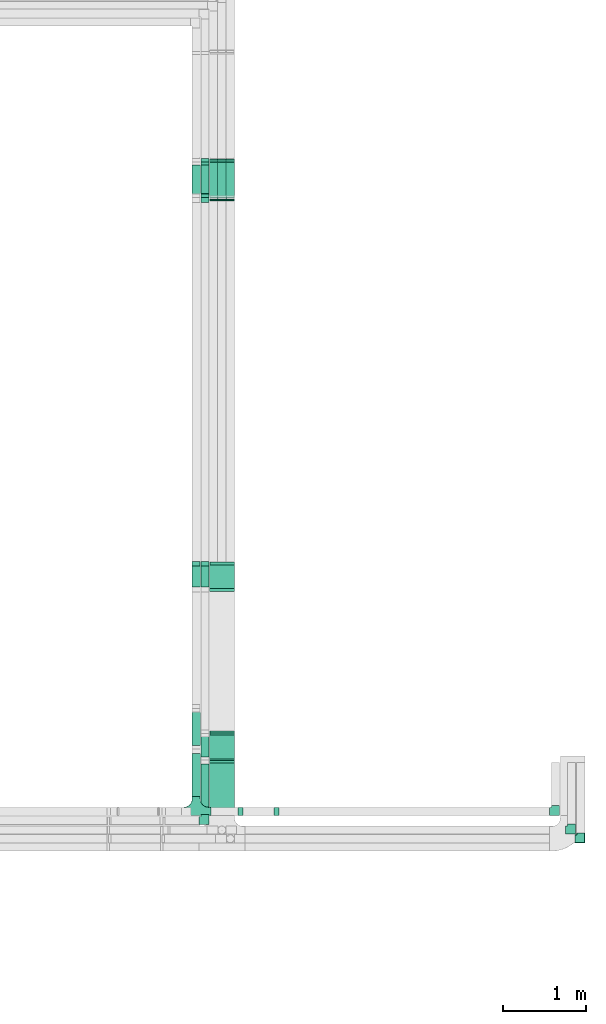
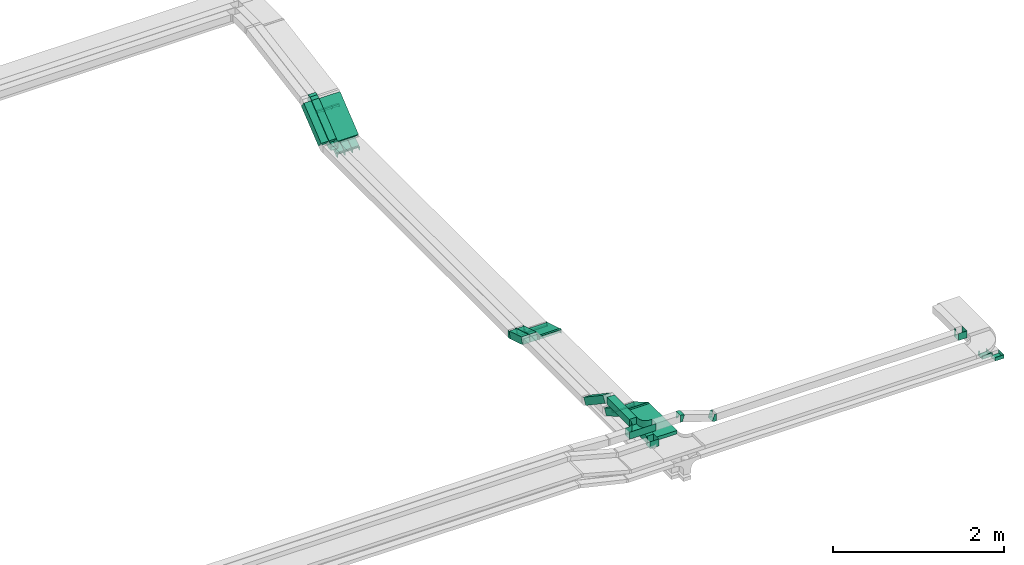
# One storey, part 11 of 14: 21 flow fittings, 15 flow segments.
"""IFC2X3 building model written with IfcOpenShell, lengths in millimetres."""

from ifc_helpers import new_model, entity, si_unit, converted_unit, derived_unit, direction, frame, frame_2d, origin, origin_2d_with_axis, place, context, subcontext, project, spatial, rectangle, extrude, faceted_brep, source, transform, mapped, material, type_object, type_shapes, element, save


model = new_model("IFC2X3")

# Units and contexts
model_context = context("Model", 3, precision=0.01, world=origin(), true_north=direction((6.12303176911189e-17, 1.0)))
body_context = subcontext(model_context, "Body", "Model", "MODEL_VIEW")
ifc_project = project(units=[si_unit("LENGTHUNIT", "METRE", prefix="MILLI"), si_unit("AREAUNIT", "SQUARE_METRE"), si_unit("VOLUMEUNIT", "CUBIC_METRE"), converted_unit("PLANEANGLEUNIT", "DEGREE", entity("IfcRatioMeasure", 0.0174532925199433), si_unit("PLANEANGLEUNIT", "RADIAN"), dimensions=[0, 0, 0, 0, 0, 0, 0]), si_unit("MASSUNIT", "GRAM", prefix="KILO"), derived_unit("MASSDENSITYUNIT", [(si_unit("MASSUNIT", "GRAM", prefix="KILO"), 1), (si_unit("LENGTHUNIT", "METRE"), -3)]), derived_unit("MOMENTOFINERTIAUNIT", [(si_unit("LENGTHUNIT", "METRE"), 4)]), si_unit("TIMEUNIT", "SECOND"), si_unit("FREQUENCYUNIT", "HERTZ"), si_unit("THERMODYNAMICTEMPERATUREUNIT", "DEGREE_CELSIUS"), derived_unit("THERMALTRANSMITTANCEUNIT", [(si_unit("MASSUNIT", "GRAM", prefix="KILO"), 1), (si_unit("THERMODYNAMICTEMPERATUREUNIT", "KELVIN"), -1), (si_unit("TIMEUNIT", "SECOND"), -3)]), derived_unit("VOLUMETRICFLOWRATEUNIT", [(si_unit("LENGTHUNIT", "METRE"), 3), (si_unit("TIMEUNIT", "SECOND"), -1)]), derived_unit("MASSFLOWRATEUNIT", [(si_unit("MASSUNIT", "GRAM", prefix="KILO"), 1), (si_unit("TIMEUNIT", "SECOND"), -1)]), derived_unit("ROTATIONALFREQUENCYUNIT", [(si_unit("TIMEUNIT", "SECOND"), -1)]), si_unit("ELECTRICCURRENTUNIT", "AMPERE"), si_unit("ELECTRICVOLTAGEUNIT", "VOLT"), si_unit("POWERUNIT", "WATT"), si_unit("FORCEUNIT", "NEWTON", prefix="KILO"), si_unit("ILLUMINANCEUNIT", "LUX"), si_unit("LUMINOUSFLUXUNIT", "LUMEN"), si_unit("LUMINOUSINTENSITYUNIT", "CANDELA"), derived_unit("USERDEFINED", [(si_unit("MASSUNIT", "GRAM", prefix="KILO"), -1), (si_unit("LENGTHUNIT", "METRE"), -2), (si_unit("TIMEUNIT", "SECOND"), 3), (si_unit("LUMINOUSFLUXUNIT", "LUMEN"), 1)]), derived_unit("LINEARVELOCITYUNIT", [(si_unit("LENGTHUNIT", "METRE"), 1), (si_unit("TIMEUNIT", "SECOND"), -1)]), si_unit("PRESSUREUNIT", "PASCAL"), derived_unit("USERDEFINED", [(si_unit("LENGTHUNIT", "METRE"), -2), (si_unit("MASSUNIT", "GRAM", prefix="KILO"), 1), (si_unit("TIMEUNIT", "SECOND"), -2)]), derived_unit("LINEARFORCEUNIT", [(si_unit("MASSUNIT", "GRAM", prefix="KILO"), 1), (si_unit("LENGTHUNIT", "METRE"), 1), (si_unit("TIMEUNIT", "SECOND"), -2), (si_unit("LENGTHUNIT", "METRE"), -1)]), derived_unit("PLANARFORCEUNIT", [(si_unit("MASSUNIT", "GRAM", prefix="KILO"), 1), (si_unit("LENGTHUNIT", "METRE"), 1), (si_unit("TIMEUNIT", "SECOND"), -2), (si_unit("LENGTHUNIT", "METRE"), -2)])], contexts=[model_context])

# Site, building, storey
site_placement = place(None, origin())
site = spatial("IfcSite", under=ifc_project, at=site_placement, CompositionType="ELEMENT")
building_placement = place(site_placement, origin())
building = spatial("IfcBuilding", under=site, at=building_placement, CompositionType="ELEMENT")
storey_placement = place(building_placement, frame((0.0, 0.0, 19800.0)))
storey = spatial("IfcBuildingStorey", under=building, at=storey_placement, CompositionType="ELEMENT", Elevation=19800.0)

# Flow segments
cable_carrier_segment_type = type_object("IfcCableCarrierSegmentType", PredefinedType="CABLETRAYSEGMENT")
flow_segment_1_placement = place(storey_placement, frame((64391.91, 17411.15, 2720.97)))
element("IfcFlowSegment", 1, at=flow_segment_1_placement, inside=storey, type_object=cable_carrier_segment_type, context=body_context, shape_type="SweptSolid", body=[
    extrude(rectangle(XDim=49.9999999999999, YDim=558.364474472639, at=frame_2d((0.0, 0.0), x_axis=(0.0, 1.0))), frame((0.0, 232.7, 195.12), z_axis=(1.0, 0.0, 0.0), x_axis=(0.0, -0.777145961456977, -0.62932039104983)), (0.0, 0.0, 1.0), 300.000000000001),
])
flow_segment_2_placement = place(storey_placement, frame((64285.53, 17401.05, 2737.88)))
element("IfcFlowSegment", 2, at=flow_segment_2_placement, inside=storey, type_object=cable_carrier_segment_type, context=body_context, shape_type="SweptSolid", body=[
    extrude(rectangle(XDim=100.000000000002, YDim=99.9999999999916, at=origin_2d_with_axis()), frame((50.02, 31.47, 38.86), z_axis=(-3.20308930122839e-05, 0.777145960996682, 0.6293203908031), x_axis=(0.0, -0.629320391125934, 0.777145961395349)), (0.0, 0.0, 1.0), 524.408740760887),
])
flow_segment_3_placement = place(storey_placement, frame((64180.06, 17401.05, 2737.88)))
element("IfcFlowSegment", 3, at=flow_segment_3_placement, inside=storey, type_object=cable_carrier_segment_type, context=body_context, shape_type="SweptSolid", body=[
    extrude(rectangle(XDim=100.000000000001, YDim=99.9999999999946, at=origin_2d_with_axis()), frame((50.0, 31.47, 38.86), z_axis=(0.0, 0.777145961456953, 0.62932039104986), x_axis=(0.0, -0.62932039104986, 0.777145961456953)), (0.0, 0.0, 1.0), 524.410565226229),
])
flow_segment_4_placement = place(storey_placement, frame((64593.04, 17401.2, 2566.87)))
element("IfcFlowSegment", 4, at=flow_segment_4_placement, inside=storey, type_object=cable_carrier_segment_type, context=body_context, shape_type="SweptSolid", body=[
    extrude(rectangle(XDim=50.0000000000052, YDim=534.379820039847, at=frame_2d((0.0, 0.0), x_axis=(0.0, 1.0))), frame((0.0, 234.43, 171.82), z_axis=(1.0, 0.0, 0.0), x_axis=(0.0, 0.824451507844614, 0.565932603065721)), (0.0, 0.0, 1.0), 99.9999999999946),
])
for number, where in (
    (5, (64490.53, 17401.2, 2566.87)),
    (6, (64388.57, 17401.2, 2566.87)),
):
    element("IfcFlowSegment", number, at=place(storey_placement, frame(where)), inside=storey, type_object=cable_carrier_segment_type, context=body_context, shape_type="SweptSolid", body=[
        extrude(rectangle(XDim=50.0000000000052, YDim=534.379820034669, at=frame_2d((0.0, 0.0), x_axis=(0.0, 1.0))), frame((0.0, 234.43, 171.82), z_axis=(1.0, 0.0, 0.0), x_axis=(0.0, 0.824451507844611, 0.565932603065725)), (0.0, 0.0, 1.0), 99.9999999999946),
    ])
flow_segment_5_placement = place(storey_placement, frame((64393.04, 9945.0, 3000.0)))
element("IfcFlowSegment", 7, at=flow_segment_5_placement, inside=storey, type_object=cable_carrier_segment_type, context=body_context, shape_type="SweptSolid", body=[
    extrude(rectangle(XDim=637.211482764682, YDim=300.000000000001, at=origin_2d_with_axis()), frame((150.0, 318.61, 0.0), z_axis=(0.0, 0.0, 1.0), x_axis=(0.0, 1.0, 0.0)), (0.0, 0.0, 1.0), 49.9999999999973),
])
flow_segment_6_placement = place(storey_placement, frame((64393.04, 10606.54, 2813.22)))
element("IfcFlowSegment", 8, at=flow_segment_6_placement, inside=storey, type_object=cable_carrier_segment_type, context=body_context, shape_type="SweptSolid", body=[
    extrude(rectangle(XDim=49.9999999999989, YDim=360.525588832415, at=frame_2d((0.0, 0.0), x_axis=(0.0, 1.0))), frame((0.0, 168.61, 111.78), z_axis=(1.0, 0.0, 0.0), x_axis=(0.0, 0.866025403784418, -0.500000000000036)), (0.0, 0.0, 1.0), 300.000000000001),
])
flow_segment_7_placement = place(storey_placement, frame((64285.55, 10605.64, 2823.27)))
element("IfcFlowSegment", 9, at=flow_segment_7_placement, inside=storey, type_object=cable_carrier_segment_type, context=body_context, shape_type="SweptSolid", body=[
    extrude(rectangle(XDim=99.9999999999989, YDim=99.9999999999946, at=origin_2d_with_axis()), frame((50.0, 25.0, 210.16), z_axis=(0.0, 0.866025403784326, -0.500000000000195), x_axis=(0.0, 0.500000000000195, 0.866025403784326)), (0.0, 0.0, 1.0), 333.724470253517),
])
flow_segment_8_placement = place(storey_placement, frame((64285.55, 9956.0, 3000.0)))
element("IfcFlowSegment", 10, at=flow_segment_8_placement, inside=storey, type_object=cable_carrier_segment_type, context=body_context, shape_type="SweptSolid", body=[
    extrude(rectangle(XDim=612.814024398429, YDim=99.9999999999946, at=origin_2d_with_axis()), frame((50.0, 306.41, 0.0), z_axis=(0.0, 0.0, 1.0), x_axis=(0.0, 1.0, 0.0)), (0.0, 0.0, 1.0), 100.000000000003),
])
flow_segment_9_placement = place(storey_placement, frame((64180.06, 10175.0, 3146.68)))
element("IfcFlowSegment", 11, at=flow_segment_9_placement, inside=storey, type_object=cable_carrier_segment_type, context=body_context, shape_type="SweptSolid", body=[
    extrude(rectangle(XDim=523.063851606019, YDim=99.9999999999946, at=origin_2d_with_axis()), frame((50.0, 261.53, 0.0), z_axis=(0.0, 0.0, 1.0), x_axis=(0.0, 1.0, 0.0)), (0.0, 0.0, 1.0), 100.000000000003),
])
flow_segment_10_placement = place(storey_placement, frame((64180.06, 10737.84, 2829.04)))
element("IfcFlowSegment", 12, at=flow_segment_10_placement, inside=storey, type_object=cable_carrier_segment_type, context=body_context, shape_type="SweptSolid", body=[
    extrude(rectangle(XDim=99.9999999999974, YDim=99.9999999999946, at=origin_2d_with_axis()), frame((50.0, 27.84, 347.08), z_axis=(0.0, 0.830647645705059, -0.556798427336718), x_axis=(0.0, 0.556798427336718, 0.830647645705059)), (0.0, 0.0, 1.0), 548.755620607478),
])
flow_segment_11_placement = place(storey_placement, frame((64393.04, 12673.69, 2704.96)))
element("IfcFlowSegment", 13, at=flow_segment_11_placement, inside=storey, type_object=cable_carrier_segment_type, context=body_context, shape_type="SweptSolid", body=[
    extrude(rectangle(XDim=50.0000000000024, YDim=315.590748852371, at=frame_2d((0.0, 0.0), x_axis=(0.0, 1.0))), frame((0.0, 158.21, 70.04), z_axis=(1.0, 0.0, 0.0), x_axis=(0.0, 0.956304755963003, -0.292371704722843)), (0.0, 0.0, 1.0), 300.000000000001),
])
flow_segment_12_placement = place(storey_placement, frame((64285.55, 12676.65, 2708.42)))
element("IfcFlowSegment", 14, at=flow_segment_12_placement, inside=storey, type_object=cable_carrier_segment_type, context=body_context, shape_type="SweptSolid", body=[
    extrude(rectangle(XDim=100.000000000005, YDim=99.9999999999946, at=frame_2d((0.0, 0.0), x_axis=(0.0, 1.0))), frame((50.0, 14.62, 135.71), z_axis=(0.0, 0.956304755963, -0.292371704722853), x_axis=(-1.0, 0.0, 0.0)), (0.0, 0.0, 1.0), 300.639738492675),
])
flow_segment_13_placement = place(storey_placement, frame((64180.06, 12676.65, 2708.42)))
element("IfcFlowSegment", 15, at=flow_segment_13_placement, inside=storey, type_object=cable_carrier_segment_type, context=body_context, shape_type="SweptSolid", body=[
    extrude(rectangle(XDim=100.000000000005, YDim=99.9999999999946, at=frame_2d((0.0, 0.0), x_axis=(0.0, 1.0))), frame((50.0, 14.62, 135.71), z_axis=(0.0, 0.956304755963006, -0.292371704722833), x_axis=(-1.0, 0.0, 0.0)), (0.0, 0.0, 1.0), 300.63847261503),
])

# Flow fittings
ifc_material = material()
cable_carrier_fitting_type_1 = type_object("IfcCableCarrierFittingType", PredefinedType="NOTDEFINED", material=ifc_material)
shared_shape_1 = source(origin(), body_context, "Body", "Brep", [
    faceted_brep([(-17.08, -25.0, 50.0), (-17.08, 25.0, 50.0), (-17.08, 25.0, 47.46), (-17.08, -22.46, 47.46), (-17.08, -22.46, -47.46), (-17.08, 25.0, -47.46), (-17.08, 25.0, -50.0), (-17.08, -25.0, -50.0), (25.98, -15.54, 50.0), (25.98, -15.54, -50.0), (5.03, 29.86, -50.0), (5.03, 29.86, -47.46), (24.92, -13.23, -47.46), (24.92, -13.23, 47.46), (5.03, 29.86, 47.46), (5.03, 29.86, 50.0), (5.49, -25.0, 50.0), (-5.49, 25.0, 50.0), (-5.49, 25.0, 47.46), (4.93, -22.46, 47.46), (4.93, -22.46, -47.46), (-5.49, 25.0, -47.46), (-5.49, 25.0, -50.0), (5.49, -25.0, -50.0)], [[[0, 1, 2, 3, 4, 5, 6, 7]], [[8, 9, 10, 11, 12, 13, 14, 15]], [[1, 0, 16, 8, 15, 17]], [[2, 1, 17, 18]], [[3, 2, 18, 14, 13, 19]], [[4, 3, 19, 20]], [[5, 4, 20, 12, 11, 21]], [[6, 5, 21, 22]], [[7, 6, 22, 10, 9, 23]], [[0, 7, 23, 16]], [[18, 17, 15, 14]], [[20, 19, 13, 12]], [[22, 21, 11, 10]], [[16, 23, 9, 8]]]),
])
type_shapes(cable_carrier_fitting_type_1, [shared_shape_1])
for number, where, z_axis, x_axis in (
    (16, (64643.04, 17870.0, 2899.57), (1.0, 0.0, 0.0), (0.0, -0.985728987268033, -0.168340023938269)),
    (17, (64540.53, 17870.0, 2899.57), (1.0, 0.0, 0.0), (0.0, -0.985728987268033, -0.168340023938269)),
    (18, (64438.57, 17870.0, 2899.57), (1.0, 0.0, 0.0), (0.0, -0.985728987268033, -0.168340023938269)),
):
    element("IfcFlowFitting", number, at=place(storey_placement, frame(where, z_axis=z_axis, x_axis=x_axis)), inside=storey, type_object=cable_carrier_fitting_type_1, material=ifc_material, context=body_context, shape_type="MappedRepresentation", body=[
        mapped(shared_shape_1, transform((0.0, 0.0, 0.0), scale=1.0)),
    ])
cable_carrier_fitting_type_2 = type_object("IfcCableCarrierFittingType", PredefinedType="NOTDEFINED", material=ifc_material)
shared_shape_2 = source(origin(), body_context, "Body", "Brep", [
    faceted_brep([(-70.0, 50.0, -25.0), (-70.0, -50.0, -25.0), (-70.0, -50.0, 25.0), (-70.0, -47.46, 25.0), (-70.0, -47.46, -22.46), (-70.0, 47.46, -22.46), (-70.0, 47.46, 25.0), (-70.0, 50.0, 25.0), (-50.0, 50.0, -25.0), (-50.0, 70.0, -25.0), (50.0, 70.0, -25.0), (50.0, -50.0, -25.0), (50.0, -50.0, 25.0), (50.0, 70.0, 25.0), (47.46, 70.0, 25.0), (47.46, -47.46, 25.0), (47.46, -47.46, -22.46), (47.46, 70.0, -22.46), (-47.46, 70.0, -22.46), (-47.46, 47.46, -22.46), (-47.46, 47.46, 25.0), (-47.46, 70.0, 25.0), (-50.0, 70.0, 25.0), (-50.0, 50.0, 25.0)], [[[0, 1, 2, 3, 4, 5, 6, 7]], [[1, 0, 8, 9, 10, 11]], [[2, 1, 11, 12]], [[3, 2, 12, 13, 14, 15]], [[4, 3, 15, 16]], [[5, 4, 16, 17, 18, 19]], [[6, 5, 19, 20]], [[7, 6, 20, 21, 22, 23]], [[0, 7, 23, 8]], [[9, 22, 21, 18, 17, 14, 13, 10]], [[12, 11, 10, 13]], [[16, 15, 14, 17]], [[20, 19, 18, 21]], [[8, 23, 22, 9]]]),
])
type_shapes(cable_carrier_fitting_type_2, [shared_shape_2])
for number, where in (
    (19, (68767.44, 9770.0, 2825.0)),
    (20, (68880.58, 9665.0, 2825.0)),
):
    element("IfcFlowFitting", number, at=place(storey_placement, frame(where)), inside=storey, type_object=cable_carrier_fitting_type_2, material=ifc_material, context=body_context, shape_type="MappedRepresentation", body=[
        mapped(shared_shape_2, transform((0.0, 0.0, 0.0), scale=1.0)),
    ])
cable_carrier_fitting_type_3 = type_object("IfcCableCarrierFittingType", PredefinedType="NOTDEFINED", material=ifc_material)
shared_shape_3 = source(origin(), body_context, "Body", "Brep", [
    faceted_brep([(-22.06, 25.0, 50.0), (-22.06, 25.0, -50.0), (-22.06, -25.0, -50.0), (-22.06, -25.0, -47.46), (-22.06, 22.46, -47.46), (-22.06, 22.46, 47.46), (-22.06, -25.0, 47.46), (-22.06, -25.0, 50.0), (4.04, 33.1, 50.0), (32.34, -8.13, 50.0), (32.34, -8.13, 47.46), (5.48, 31.0, 47.46), (5.48, 31.0, -47.46), (32.34, -8.13, -47.46), (32.34, -8.13, -50.0), (4.04, 33.1, -50.0), (-7.75, 25.0, 50.0), (-7.75, 25.0, -50.0), (7.75, -25.0, -50.0), (7.75, -25.0, -47.46), (-6.97, 22.46, -47.46), (-6.97, 22.46, 47.46), (7.75, -25.0, 47.46), (7.75, -25.0, 50.0)], [[[0, 1, 2, 3, 4, 5, 6, 7]], [[8, 9, 10, 11, 12, 13, 14, 15]], [[1, 0, 16, 17]], [[2, 1, 17, 15, 14, 18]], [[3, 2, 18, 19]], [[4, 3, 19, 13, 12, 20]], [[5, 4, 20, 21]], [[6, 5, 21, 11, 10, 22]], [[7, 6, 22, 23]], [[0, 7, 23, 9, 8, 16]], [[17, 16, 8, 15]], [[19, 18, 14, 13]], [[21, 20, 12, 11]], [[23, 22, 10, 9]]]),
])
type_shapes(cable_carrier_fitting_type_3, [shared_shape_3])
for number, where, z_axis, x_axis in (
    (21, (64643.04, 17397.16, 2575.0), (-1.0, 0.0, 0.0), (0.0, -0.824451507844615, -0.565932603065719)),
    (22, (64540.53, 17397.16, 2575.0), (-1.0, 0.0, 0.0), (0.0, -0.824451507844612, -0.565932603065724)),
    (23, (64438.57, 17397.16, 2575.0), (-1.0, 0.0, 0.0), (0.0, -0.824451507844612, -0.565932603065724)),
):
    element("IfcFlowFitting", number, at=place(storey_placement, frame(where, z_axis=z_axis, x_axis=x_axis)), inside=storey, type_object=cable_carrier_fitting_type_3, material=ifc_material, context=body_context, shape_type="MappedRepresentation", body=[
        mapped(shared_shape_3, transform((0.0, 0.0, 0.0), scale=1.0)),
    ])
cable_carrier_fitting_type_4 = type_object("IfcCableCarrierFittingType", PredefinedType="NOTDEFINED", material=ifc_material)
shared_shape_4 = source(origin(), body_context, "Body", "Brep", [
    faceted_brep([(-19.74, -25.0, 150.0), (-19.74, 25.0, 150.0), (-19.74, 25.0, 147.46), (-19.74, -22.46, 147.46), (-19.74, -22.46, -147.46), (-19.74, 25.0, -147.46), (-19.74, 25.0, -150.0), (-19.74, -25.0, -150.0), (29.59, -11.78, 150.0), (29.59, -11.78, -150.0), (4.59, 31.52, -150.0), (4.59, 31.52, -147.46), (28.32, -9.58, -147.46), (28.32, -9.58, 147.46), (4.59, 31.52, 147.46), (4.59, 31.52, 150.0), (6.7, -25.0, 150.0), (-6.7, 25.0, 150.0), (-6.7, 25.0, 147.46), (6.02, -22.46, 147.46), (6.02, -22.46, -147.46), (-6.7, 25.0, -147.46), (-6.7, 25.0, -150.0), (6.7, -25.0, -150.0)], [[[0, 1, 2, 3, 4, 5, 6, 7]], [[8, 9, 10, 11, 12, 13, 14, 15]], [[1, 0, 16, 8, 15, 17]], [[2, 1, 17, 18]], [[3, 2, 18, 14, 13, 19]], [[4, 3, 19, 20]], [[5, 4, 20, 12, 11, 21]], [[6, 5, 21, 22]], [[7, 6, 22, 10, 9, 23]], [[0, 7, 23, 16]], [[18, 17, 15, 14]], [[20, 19, 13, 12]], [[22, 21, 11, 10]], [[16, 23, 9, 8]]]),
])
type_shapes(cable_carrier_fitting_type_4, [shared_shape_4])
for number, where, z_axis, x_axis in (
    (24, (64543.04, 10601.95, 3025.0), (-1.0, 0.0, 0.0), (0.0, 1.0, 0.0)),
    (25, (64543.04, 10948.36, 2825.0), (1.0, 0.0, 0.0), (0.0, 0.866025403784418, -0.500000000000036)),
):
    element("IfcFlowFitting", number, at=place(storey_placement, frame(where, z_axis=z_axis, x_axis=x_axis)), inside=storey, type_object=cable_carrier_fitting_type_4, material=ifc_material, context=body_context, shape_type="MappedRepresentation", body=[
        mapped(shared_shape_4, transform((0.0, 0.0, 0.0), scale=1.0)),
    ])
cable_carrier_fitting_type_5 = type_object("IfcCableCarrierFittingType", PredefinedType="NOTDEFINED", material=ifc_material)
shared_shape_5 = source(origin(), body_context, "Body", "Brep", [
    faceted_brep([(-70.0, 50.0, -50.0), (-70.0, -50.0, -50.0), (-70.0, -50.0, 50.0), (-70.0, -47.46, 50.0), (-70.0, -47.46, -47.46), (-70.0, 47.46, -47.46), (-70.0, 47.46, 50.0), (-70.0, 50.0, 50.0), (-50.0, 50.0, -50.0), (-50.0, 70.0, -50.0), (50.0, 70.0, -50.0), (50.0, -50.0, -50.0), (50.0, -50.0, 50.0), (50.0, 70.0, 50.0), (47.46, 70.0, 50.0), (47.46, -47.46, 50.0), (47.46, -47.46, -47.46), (47.46, 70.0, -47.46), (-47.46, 70.0, -47.46), (-47.46, 47.46, -47.46), (-47.46, 47.46, 50.0), (-47.46, 70.0, 50.0), (-50.0, 70.0, 50.0), (-50.0, 50.0, 50.0)], [[[0, 1, 2, 3, 4, 5, 6, 7]], [[1, 0, 8, 9, 10, 11]], [[2, 1, 11, 12]], [[3, 2, 12, 13, 14, 15]], [[4, 3, 15, 16]], [[5, 4, 16, 17, 18, 19]], [[6, 5, 19, 20]], [[7, 6, 20, 21, 22, 23]], [[0, 7, 23, 8]], [[9, 22, 21, 18, 17, 14, 13, 10]], [[12, 11, 10, 13]], [[16, 15, 14, 17]], [[20, 19, 18, 21]], [[8, 23, 22, 9]]]),
])
type_shapes(cable_carrier_fitting_type_5, [shared_shape_5])
flow_fitting_1_placement = place(storey_placement, frame((68573.26, 9995.0, 3050.0)))
element("IfcFlowFitting", 26, at=flow_fitting_1_placement, inside=storey, type_object=cable_carrier_fitting_type_5, material=ifc_material, context=body_context, shape_type="MappedRepresentation", body=[
    mapped(shared_shape_5, transform((0.0, 0.0, 0.0), scale=1.0)),
])
cable_carrier_fitting_type_6 = type_object("IfcCableCarrierFittingType", PredefinedType="NOTDEFINED", material=ifc_material)
type_shapes(cable_carrier_fitting_type_6, [shared_shape_5])
flow_fitting_2_placement = place(storey_placement, frame((64335.55, 9886.0, 3050.0)))
element("IfcFlowFitting", 27, at=flow_fitting_2_placement, inside=storey, type_object=cable_carrier_fitting_type_6, material=ifc_material, context=body_context, shape_type="MappedRepresentation", body=[
    mapped(shared_shape_5, transform((0.0, 0.0, 0.0), scale=1.0)),
])
cable_carrier_fitting_type_7 = type_object("IfcCableCarrierFittingType", PredefinedType="NOTDEFINED", material=ifc_material)
shared_shape_6 = source(origin(), body_context, "Body", "Brep", [
    faceted_brep([(-53.41, -124.12, 50.0), (-50.0, -150.0, 50.0), (-50.0, -180.0, 50.0), (-49.2, -180.0, 50.0), (-49.2, -150.0, 50.0), (-52.63, -123.91, 50.0), (-62.7, -99.6, 50.0), (-78.72, -78.72, 50.0), (-99.6, -62.7, 50.0), (-123.91, -52.63, 50.0), (-150.0, -49.2, 50.0), (-180.0, -49.2, 50.0), (-180.0, -50.0, 50.0), (-150.0, -50.0, 50.0), (-124.12, -53.41, 50.0), (-100.0, -63.4, 50.0), (-79.29, -79.29, 50.0), (-63.4, -100.0, 50.0), (180.0, -50.0, 50.0), (180.0, -49.2, 50.0), (150.0, -49.2, 50.0), (123.91, -52.63, 50.0), (99.6, -62.7, 50.0), (78.72, -78.72, 50.0), (62.7, -99.6, 50.0), (52.63, -123.91, 50.0), (49.2, -150.0, 50.0), (49.2, -180.0, 50.0), (50.0, -180.0, 50.0), (50.0, -150.0, 50.0), (53.41, -124.12, 50.0), (63.4, -100.0, 50.0), (79.29, -79.29, 50.0), (100.0, -63.4, 50.0), (124.12, -53.41, 50.0), (150.0, -50.0, 50.0), (180.0, 49.2, 50.0), (180.0, 50.0, 50.0), (-180.0, 50.0, 50.0), (-180.0, 49.2, 50.0), (-180.0, -50.0, -50.0), (-180.0, 50.0, -50.0), (180.0, 50.0, -50.0), (180.0, -50.0, -50.0), (150.0, -50.0, -50.0), (124.12, -53.41, -50.0), (100.0, -63.4, -50.0), (79.29, -79.29, -50.0), (63.4, -100.0, -50.0), (53.41, -124.12, -50.0), (50.0, -150.0, -50.0), (50.0, -180.0, -50.0), (-50.0, -180.0, -50.0), (-50.0, -150.0, -50.0), (-53.41, -124.12, -50.0), (-63.4, -100.0, -50.0), (-79.29, -79.29, -50.0), (-100.0, -63.4, -50.0), (-124.12, -53.41, -50.0), (-150.0, -50.0, -50.0), (-50.0, -150.0, -49.2), (49.2, -180.0, -49.2), (-49.2, -180.0, -49.2), (-49.2, -150.0, -49.2), (-150.0, -49.2, -49.2), (-180.0, -49.2, -49.2), (180.0, -49.2, -49.2), (150.0, -49.2, -49.2), (-180.0, 49.2, -49.2), (-150.0, -50.0, -49.2), (150.0, -50.0, -49.2), (180.0, 49.2, -49.2), (49.2, -150.0, -49.2), (50.0, -150.0, -49.2), (-123.91, -52.63, -49.2), (-99.6, -62.7, -49.2), (-78.72, -78.72, -49.2), (-62.7, -99.6, -49.2), (-52.63, -123.91, -49.2), (52.63, -123.91, -49.2), (62.7, -99.6, -49.2), (78.72, -78.72, -49.2), (99.6, -62.7, -49.2), (123.91, -52.63, -49.2)], [[[0, 1, 2, 3, 4, 5, 6, 7, 8, 9, 10, 11, 12, 13, 14, 15, 16, 17]], [[18, 19, 20, 21, 22, 23, 24, 25, 26, 27, 28, 29, 30, 31, 32, 33, 34, 35]], [[36, 37, 38, 39]], [[40, 41, 42, 43, 44, 45, 46, 47, 48, 49, 50, 51, 52, 53, 54, 55, 56, 57, 58, 59]], [[2, 1, 60, 53, 52]], [[3, 2, 52, 51, 28, 27, 61, 62]], [[4, 3, 62, 63]], [[11, 10, 64, 65]], [[20, 19, 66, 67]], [[39, 38, 41, 40, 12, 11, 65, 68]], [[13, 12, 40, 59, 69]], [[18, 35, 70, 44, 43]], [[19, 18, 43, 42, 37, 36, 71, 66]], [[27, 26, 72, 61]], [[29, 28, 51, 50, 73]], [[38, 37, 42, 41]], [[36, 39, 68, 71]], [[68, 65, 64, 74, 75, 76, 77, 78, 63, 62, 61, 72, 79, 80, 81, 82, 83, 67, 66, 71]], [[14, 13, 69, 59, 58]], [[15, 14, 58, 57]], [[57, 56, 16, 15]], [[17, 16, 56, 55]], [[0, 17, 55, 54]], [[1, 0, 54, 53, 60]], [[5, 78, 77, 6]], [[6, 77, 76, 7]], [[63, 78, 5, 4]], [[8, 75, 74, 9]], [[9, 74, 64, 10]], [[7, 76, 75, 8]], [[21, 83, 82, 22]], [[22, 82, 81, 23]], [[67, 83, 21, 20]], [[24, 80, 79, 25]], [[25, 79, 72, 26]], [[23, 81, 80, 24]], [[30, 29, 73, 50, 49]], [[31, 30, 49, 48]], [[32, 31, 48, 47]], [[34, 33, 46, 45]], [[34, 45, 44, 70, 35]], [[46, 33, 32, 47]]]),
])
type_shapes(cable_carrier_fitting_type_7, [shared_shape_6])
flow_fitting_3_placement = place(storey_placement, frame((64230.06, 9995.0, 3196.68), z_axis=(0.0, 0.0, 1.0), x_axis=(-1.0, 0.0, 0.0)))
element("IfcFlowFitting", 28, at=flow_fitting_3_placement, inside=storey, type_object=cable_carrier_fitting_type_7, material=ifc_material, Name="470_DKC_S5_T", context=body_context, shape_type="MappedRepresentation", body=[
    mapped(shared_shape_6, transform((0.0, 0.0, 0.0), scale=1.0)),
])
cable_carrier_fitting_type_8 = type_object("IfcCableCarrierFittingType", PredefinedType="NOTDEFINED", material=ifc_material)
shared_shape_7 = source(origin(), body_context, "Body", "Brep", [
    faceted_brep([(-21.78, -50.0, 50.0), (-21.78, 50.0, 50.0), (-21.78, 50.0, 47.46), (-21.78, -47.46, 47.46), (-21.78, -47.46, -47.46), (-21.78, 50.0, -47.46), (-21.78, 50.0, -50.0), (-21.78, -50.0, -50.0), (36.28, -40.72, 50.0), (36.28, -40.72, -50.0), (5.11, 54.3, -50.0), (5.11, 54.3, -47.46), (35.49, -38.31, -47.46), (35.49, -38.31, 47.46), (5.11, 54.3, 47.46), (5.11, 54.3, 50.0), (7.99, -50.0, 50.0), (-7.99, 50.0, 50.0), (-7.99, 50.0, 47.46), (7.59, -47.46, 47.46), (7.59, -47.46, -47.46), (-7.99, 50.0, -47.46), (-7.99, 50.0, -50.0), (7.99, -50.0, -50.0)], [[[0, 1, 2, 3, 4, 5, 6, 7]], [[8, 9, 10, 11, 12, 13, 14, 15]], [[1, 0, 16, 8, 15, 17]], [[2, 1, 17, 18]], [[3, 2, 18, 14, 13, 19]], [[4, 3, 19, 20]], [[5, 4, 20, 12, 11, 21]], [[6, 5, 21, 22]], [[7, 6, 22, 10, 9, 23]], [[0, 7, 23, 16]], [[18, 17, 15, 14]], [[20, 19, 13, 12]], [[22, 21, 11, 10]], [[16, 23, 9, 8]]]),
])
type_shapes(cable_carrier_fitting_type_8, [shared_shape_7])
for number, where, z_axis, x_axis in (
    (29, (65207.18, 9995.0, 3050.0), (0.0, 1.0, 0.0), (-1.0, 0.0, 0.0)),
    (30, (64760.06, 9995.0, 3196.68), (0.0, 1.0, 0.0), (1.0, 0.0, 0.0)),
):
    element("IfcFlowFitting", number, at=place(storey_placement, frame(where, z_axis=z_axis, x_axis=x_axis)), inside=storey, type_object=cable_carrier_fitting_type_8, material=ifc_material, context=body_context, shape_type="MappedRepresentation", body=[
        mapped(shared_shape_7, transform((0.0, 0.0, 0.0), scale=1.0)),
    ])
cable_carrier_fitting_type_9 = type_object("IfcCableCarrierFittingType", PredefinedType="NOTDEFINED", material=ifc_material)
shared_shape_8 = source(origin(), body_context, "Body", "Brep", [
    faceted_brep([(-13.22, -25.0, 150.0), (-13.22, 25.0, 150.0), (-13.22, 25.0, 147.46), (-13.22, -22.46, 147.46), (-13.22, -22.46, -147.46), (-13.22, 25.0, -147.46), (-13.22, 25.0, -150.0), (-13.22, -25.0, -150.0), (19.95, -20.04, 150.0), (19.95, -20.04, -150.0), (5.33, 27.77, -150.0), (5.33, 27.77, -147.46), (19.21, -17.61, -147.46), (19.21, -17.61, 147.46), (5.33, 27.77, 147.46), (5.33, 27.77, 150.0), (3.74, -25.0, 150.0), (-3.74, 25.0, 150.0), (-3.74, 25.0, 147.46), (3.36, -22.46, 147.46), (3.36, -22.46, -147.46), (-3.74, 25.0, -147.46), (-3.74, 25.0, -150.0), (3.74, -25.0, -150.0)], [[[0, 1, 2, 3, 4, 5, 6, 7]], [[8, 9, 10, 11, 12, 13, 14, 15]], [[1, 0, 16, 8, 15, 17]], [[2, 1, 17, 18]], [[3, 2, 18, 14, 13, 19]], [[4, 3, 19, 20]], [[5, 4, 20, 12, 11, 21]], [[6, 5, 21, 22]], [[7, 6, 22, 10, 9, 23]], [[0, 7, 23, 16]], [[18, 17, 15, 14]], [[20, 19, 13, 12]], [[22, 21, 11, 10]], [[16, 23, 9, 8]]]),
])
type_shapes(cable_carrier_fitting_type_9, [shared_shape_8])
flow_fitting_4_placement = place(storey_placement, frame((64543.04, 12668.36, 2825.0), z_axis=(-1.0, 0.0, 0.0), x_axis=(0.0, 1.0, 0.0)))
element("IfcFlowFitting", 31, at=flow_fitting_4_placement, inside=storey, type_object=cable_carrier_fitting_type_9, material=ifc_material, context=body_context, shape_type="MappedRepresentation", body=[
    mapped(shared_shape_8, transform((0.0, 0.0, 0.0), scale=1.0)),
])
cable_carrier_fitting_type_10 = type_object("IfcCableCarrierFittingType", PredefinedType="NOTDEFINED", material=ifc_material)
type_shapes(cable_carrier_fitting_type_10, [shared_shape_8])
flow_fitting_5_placement = place(storey_placement, frame((64543.04, 12995.44, 2725.0), z_axis=(0.999999620565847, 0.000254693878166535, 0.00083306613831253), x_axis=(0.0, 0.956304755963, -0.292371704722852)))
element("IfcFlowFitting", 32, at=flow_fitting_5_placement, inside=storey, type_object=cable_carrier_fitting_type_10, material=ifc_material, context=body_context, shape_type="MappedRepresentation", body=[
    mapped(shared_shape_8, transform((0.0, 0.0, 0.0), scale=1.0)),
])
cable_carrier_fitting_type_11 = type_object("IfcCableCarrierFittingType", PredefinedType="NOTDEFINED", material=ifc_material)
shared_shape_9 = source(origin(), body_context, "Body", "Brep", [
    faceted_brep([(-20.69, -50.0, 50.0), (-20.69, 50.0, 50.0), (-20.69, 50.0, 47.46), (-20.69, -47.46, 47.46), (-20.69, -47.46, -47.46), (-20.69, 50.0, -47.46), (-20.69, 50.0, -50.0), (-20.69, -50.0, -50.0), (34.41, -41.77, 50.0), (34.41, -41.77, -50.0), (5.17, 53.87, -50.0), (5.17, 53.87, -47.46), (33.66, -39.34, -47.46), (33.66, -39.34, 47.46), (5.17, 53.87, 47.46), (5.17, 53.87, 50.0), (7.47, -50.0, 50.0), (-7.47, 50.0, 50.0), (-7.47, 50.0, 47.46), (7.09, -47.46, 47.46), (7.09, -47.46, -47.46), (-7.47, 50.0, -47.46), (-7.47, 50.0, -50.0), (7.47, -50.0, -50.0)], [[[0, 1, 2, 3, 4, 5, 6, 7]], [[8, 9, 10, 11, 12, 13, 14, 15]], [[1, 0, 16, 8, 15, 17]], [[2, 1, 17, 18]], [[3, 2, 18, 14, 13, 19]], [[4, 3, 19, 20]], [[5, 4, 20, 12, 11, 21]], [[6, 5, 21, 22]], [[7, 6, 22, 10, 9, 23]], [[0, 7, 23, 16]], [[18, 17, 15, 14]], [[20, 19, 13, 12]], [[22, 21, 11, 10]], [[16, 23, 9, 8]]]),
])
type_shapes(cable_carrier_fitting_type_11, [shared_shape_9])
for number, where, z_axis, x_axis in (
    (33, (64335.55, 12998.56, 2750.19), (1.0, 0.0, 0.0), (0.0, 0.956304755963004, -0.292371704722839)),
    (34, (64230.06, 12998.56, 2750.19), (1.0, 9.64493499714813e-08, 3.15471608905215e-07), (0.0, 0.95630475596301, -0.29237170472282)),
):
    element("IfcFlowFitting", number, at=place(storey_placement, frame(where, z_axis=z_axis, x_axis=x_axis)), inside=storey, type_object=cable_carrier_fitting_type_11, material=ifc_material, context=body_context, shape_type="MappedRepresentation", body=[
        mapped(shared_shape_9, transform((0.0, 0.0, 0.0), scale=1.0)),
    ])
cable_carrier_fitting_type_12 = type_object("IfcCableCarrierFittingType", PredefinedType="NOTDEFINED", material=ifc_material)
shared_shape_10 = source(origin(), body_context, "Body", "Brep", [
    faceted_brep([(-32.46, -50.0, 50.0), (-32.46, 50.0, 50.0), (-32.46, 50.0, 47.46), (-32.46, -47.46, 47.46), (-32.46, -47.46, -47.46), (-32.46, 50.0, -47.46), (-32.46, 50.0, -50.0), (-32.46, -50.0, -50.0), (52.78, -27.71, 50.0), (52.78, -27.71, -50.0), (3.83, 59.49, -50.0), (3.83, 59.49, -47.46), (51.53, -25.5, -47.46), (51.53, -25.5, 47.46), (3.83, 59.49, 47.46), (3.83, 59.49, 50.0), (13.07, -50.0, 50.0), (-13.07, 50.0, 50.0), (-13.07, 50.0, 47.46), (12.41, -47.46, 47.46), (12.41, -47.46, -47.46), (-13.07, 50.0, -47.46), (-13.07, 50.0, -50.0), (13.07, -50.0, -50.0)], [[[0, 1, 2, 3, 4, 5, 6, 7]], [[8, 9, 10, 11, 12, 13, 14, 15]], [[1, 0, 16, 8, 15, 17]], [[2, 1, 17, 18]], [[3, 2, 18, 14, 13, 19]], [[4, 3, 19, 20]], [[5, 4, 20, 12, 11, 21]], [[6, 5, 21, 22]], [[7, 6, 22, 10, 9, 23]], [[0, 7, 23, 16]], [[18, 17, 15, 14]], [[20, 19, 13, 12]], [[22, 21, 11, 10]], [[16, 23, 9, 8]]]),
])
type_shapes(cable_carrier_fitting_type_12, [shared_shape_10])
flow_fitting_6_placement = place(storey_placement, frame((64335.53, 17865.28, 3127.18), z_axis=(0.999999997859196, -1.10151596796415e-05, 6.45001820814154e-05), x_axis=(0.0, -0.985728987268032, -0.168340023938277)))
element("IfcFlowFitting", 35, at=flow_fitting_6_placement, inside=storey, type_object=cable_carrier_fitting_type_12, material=ifc_material, context=body_context, shape_type="MappedRepresentation", body=[
    mapped(shared_shape_10, transform((0.0, 0.0, 0.0), scale=1.0)),
])
cable_carrier_fitting_type_13 = type_object("IfcCableCarrierFittingType", PredefinedType="NOTDEFINED", material=ifc_material)
shared_shape_11 = source(origin(), body_context, "Body", "Brep", [
    faceted_brep([(-42.18, -50.0, 50.0), (-42.18, 50.0, 50.0), (-42.18, 50.0, 47.46), (-42.18, -47.46, 47.46), (-42.18, -47.46, -47.46), (-42.18, 50.0, -47.46), (-42.18, 50.0, -50.0), (-42.18, -50.0, -50.0), (64.25, -12.31, 50.0), (64.25, -12.31, -50.0), (1.32, 65.4, -50.0), (1.32, 65.4, -47.46), (62.65, -10.34, -47.46), (62.65, -10.34, 47.46), (1.32, 65.4, 47.46), (1.32, 65.4, 50.0), (17.71, -50.0, 50.0), (-17.71, 50.0, 50.0), (-17.71, 50.0, 47.46), (16.81, -47.46, 47.46), (16.81, -47.46, -47.46), (-17.71, 50.0, -47.46), (-17.71, 50.0, -50.0), (17.71, -50.0, -50.0)], [[[0, 1, 2, 3, 4, 5, 6, 7]], [[8, 9, 10, 11, 12, 13, 14, 15]], [[1, 0, 16, 8, 15, 17]], [[2, 1, 17, 18]], [[3, 2, 18, 14, 13, 19]], [[4, 3, 19, 20]], [[5, 4, 20, 12, 11, 21]], [[6, 5, 21, 22]], [[7, 6, 22, 10, 9, 23]], [[0, 7, 23, 16]], [[18, 17, 15, 14]], [[20, 19, 13, 12]], [[22, 21, 11, 10]], [[16, 23, 9, 8]]]),
])
type_shapes(cable_carrier_fitting_type_13, [shared_shape_11])
flow_fitting_7_placement = place(storey_placement, frame((64335.55, 17399.74, 2750.19), z_axis=(1.0, 0.0, 5.08976093732552e-05), x_axis=(0.0, 1.0, 2.64388586211518e-07)))
element("IfcFlowFitting", 36, at=flow_fitting_7_placement, inside=storey, type_object=cable_carrier_fitting_type_13, material=ifc_material, context=body_context, shape_type="MappedRepresentation", body=[
    mapped(shared_shape_11, transform((0.0, 0.0, 0.0), scale=1.0)),
])

save(model, "model.ifc")
